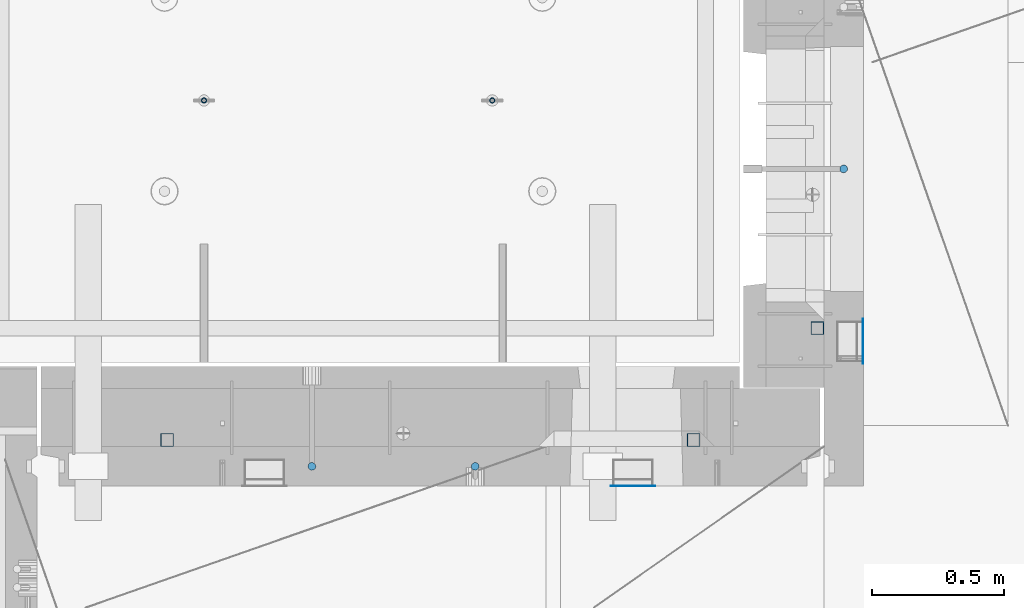
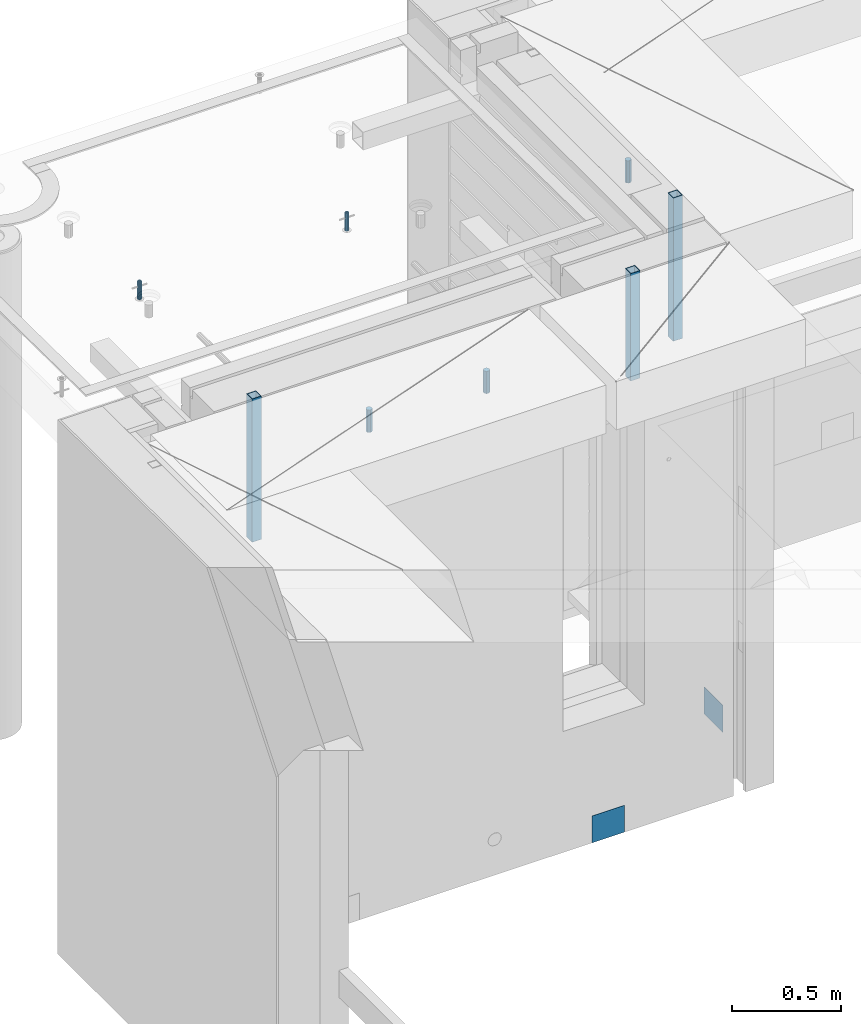
# One storey, part 27 of 350: 10 columns, 10 elements without a shape of their own.
"""IFC2X3 building model written with IfcOpenShell, lengths in millimetres."""

from ifc_helpers import new_model, si_unit, frame, origin_with_axes, place, context, subcontext, project, spatial, faceted_brep, material, type_object, element, aggregate, save


model = new_model("IFC2X3")

# Units and contexts
model_context = context("Model", 3, precision=1e-05, world=origin_with_axes())
body_context = subcontext(model_context, "Body", "Model", "MODEL_VIEW")
ifc_project = project(units=[si_unit("LENGTHUNIT", "METRE", prefix="MILLI"), si_unit("AREAUNIT", "SQUARE_METRE"), si_unit("VOLUMEUNIT", "CUBIC_METRE"), si_unit("MASSUNIT", "GRAM", prefix="KILO"), si_unit("TIMEUNIT", "SECOND"), si_unit("PLANEANGLEUNIT", "RADIAN"), si_unit("SOLIDANGLEUNIT", "STERADIAN"), si_unit("THERMODYNAMICTEMPERATUREUNIT", "DEGREE_CELSIUS"), si_unit("LUMINOUSINTENSITYUNIT", "LUMEN")], contexts=[model_context])

# Site, building, storey
site_placement = place(None, origin_with_axes())
site = spatial("IfcSite", under=ifc_project, at=site_placement, CompositionType="ELEMENT")
building_placement = place(site_placement, origin_with_axes())
building = spatial("IfcBuilding", under=site, at=building_placement, CompositionType="ELEMENT")
storey_placement = place(building_placement, origin_with_axes())
storey = spatial("IfcBuildingStorey", under=building, at=storey_placement, Name="2", CompositionType="ELEMENT", Elevation=0.0)

# Assembly, column
assembly_1_placement = place(storey_placement, origin_with_axes())
assembly_1 = element("IfcElementAssembly", 1, at=assembly_1_placement, inside=storey, AssemblyPlace="NOTDEFINED", PredefinedType="REINFORCEMENT_UNIT")
ifc_material_1 = material()
column_type_1 = type_object("IfcColumnType", Name="D30", PredefinedType="NOTDEFINED")
column_1_placement = place(assembly_1_placement, frame((11064.9999999907, 21634.9982799657, 87407.5), z_axis=(1.0, 0.0, 0.0), x_axis=(0.0, 0.0, 1.0)))
column_1 = element("IfcColumn", 2, at=column_1_placement, type_object=column_type_1, material=ifc_material_1, ObjectType="D30", context=body_context, shape_type="Brep", body=[
    faceted_brep([(0.0, -15.0, 0.0), (0.0, -12.9903810567666, -7.5), (125.0, -12.9903810567666, -7.5), (125.0, -15.0, 0.0), (0.0, -7.5, -12.9903810567666), (125.0, -7.5, -12.9903810567666), (0.0, 0.0, -15.0), (125.0, 0.0, -15.0), (0.0, 7.5, -12.9903810567666), (125.0, 7.5, -12.9903810567666), (0.0, 12.9903810567666, -7.5), (125.0, 12.9903810567666, -7.5), (0.0, 15.0, 0.0), (125.0, 15.0, 0.0), (0.0, 12.9903810567666, 7.5), (125.0, 12.9903810567666, 7.5), (0.0, 7.5, 12.9903810567666), (125.0, 7.5, 12.9903810567666), (0.0, 0.0, 15.0), (125.0, 0.0, 15.0), (0.0, -7.5, 12.9903810567666), (125.0, -7.5, 12.9903810567666), (0.0, -12.9903810567666, 7.5), (125.0, -12.9903810567666, 7.5)], [[[0, 1, 2, 3]], [[1, 4, 5, 2]], [[4, 6, 7, 5]], [[6, 8, 9, 7]], [[8, 10, 11, 9]], [[10, 12, 13, 11]], [[12, 14, 15, 13]], [[14, 16, 17, 15]], [[16, 18, 19, 17]], [[18, 20, 21, 19]], [[20, 22, 23, 21]], [[22, 0, 3, 23]], [[5, 7, 9, 11, 13, 15, 17, 19, 21, 23, 3, 2]], [[22, 20, 18, 16, 14, 12, 10, 8, 6, 4, 1, 0]]]),
])

# Assembly, columns
assembly_2_placement = place(storey_placement, origin_with_axes())
assembly_2 = element("IfcElementAssembly", 3, at=assembly_2_placement, inside=storey, AssemblyPlace="NOTDEFINED", PredefinedType="REINFORCEMENT_UNIT")
column_2_placement = place(assembly_2_placement, frame((9665.00172003435, 20504.9951872276, 87407.5), z_axis=(0.0, 1.0, 0.0), x_axis=(0.0, 0.0, 1.0)))
column_2 = element("IfcColumn", 4, at=column_2_placement, type_object=column_type_1, material=ifc_material_1, ObjectType="D30", context=body_context, shape_type="Brep", body=[
    faceted_brep([(0.0, -15.0, 0.0), (0.0, -12.9903810567666, -7.5), (125.0, -12.9903810567666, -7.5), (125.0, -15.0, 0.0), (0.0, -7.5, -12.9903810567666), (125.0, -7.5, -12.9903810567666), (0.0, 0.0, -15.0), (125.0, 0.0, -15.0), (0.0, 7.5, -12.9903810567666), (125.0, 7.5, -12.9903810567666), (0.0, 12.9903810567666, -7.5), (125.0, 12.9903810567666, -7.5), (0.0, 15.0, 0.0), (125.0, 15.0, 0.0), (0.0, 12.9903810567666, 7.5), (125.0, 12.9903810567666, 7.5), (0.0, 7.5, 12.9903810567666), (125.0, 7.5, 12.9903810567666), (0.0, 0.0, 15.0), (125.0, 0.0, 15.0), (0.0, -7.5, 12.9903810567666), (125.0, -7.5, 12.9903810567666), (0.0, -12.9903810567666, 7.5), (125.0, -12.9903810567666, 7.5)], [[[0, 1, 2, 3]], [[1, 4, 5, 2]], [[4, 6, 7, 5]], [[6, 8, 9, 7]], [[8, 10, 11, 9]], [[10, 12, 13, 11]], [[12, 14, 15, 13]], [[14, 16, 17, 15]], [[16, 18, 19, 17]], [[18, 20, 21, 19]], [[20, 22, 23, 21]], [[22, 0, 3, 23]], [[5, 7, 9, 11, 13, 15, 17, 19, 21, 23, 3, 2]], [[22, 20, 18, 16, 14, 12, 10, 8, 6, 4, 1, 0]]]),
])
column_3_placement = place(assembly_2_placement, frame((9045.00366673532, 20504.9951872205, 87407.5), z_axis=(0.0, -1.0, 0.0), x_axis=(0.0, 0.0, 1.0)))
column_3 = element("IfcColumn", 5, at=column_3_placement, type_object=column_type_1, material=ifc_material_1, ObjectType="D30", context=body_context, shape_type="Brep", body=[
    faceted_brep([(0.0, -15.0, 0.0), (0.0, -12.9903810567666, -7.5), (125.0, -12.9903810567666, -7.5), (125.0, -15.0, 0.0), (0.0, -7.5, -12.9903810567666), (125.0, -7.5, -12.9903810567666), (0.0, 0.0, -15.0), (125.0, 0.0, -15.0), (0.0, 7.5, -12.9903810567666), (125.0, 7.5, -12.9903810567666), (0.0, 12.9903810567666, -7.5), (125.0, 12.9903810567666, -7.5), (0.0, 15.0, 0.0), (125.0, 15.0, 0.0), (0.0, 12.9903810567666, 7.5), (125.0, 12.9903810567666, 7.5), (0.0, 7.5, 12.9903810567666), (125.0, 7.5, 12.9903810567666), (0.0, 0.0, 15.0), (125.0, 0.0, 15.0), (0.0, -7.5, 12.9903810567666), (125.0, -7.5, 12.9903810567666), (0.0, -12.9903810567666, 7.5), (125.0, -12.9903810567666, 7.5)], [[[0, 1, 2, 3]], [[1, 4, 5, 2]], [[4, 6, 7, 5]], [[6, 8, 9, 7]], [[8, 10, 11, 9]], [[10, 12, 13, 11]], [[12, 14, 15, 13]], [[14, 16, 17, 15]], [[16, 18, 19, 17]], [[18, 20, 21, 19]], [[20, 22, 23, 21]], [[22, 0, 3, 23]], [[5, 7, 9, 11, 13, 15, 17, 19, 21, 23, 3, 2]], [[22, 20, 18, 16, 14, 12, 10, 8, 6, 4, 1, 0]]]),
])

# Assembly, column
assembly_3_placement = place(assembly_1_placement, origin_with_axes())
assembly_3 = element("IfcElementAssembly", 6, at=assembly_3_placement, Name="Steel Assembly", AssemblyPlace="NOTDEFINED", PredefinedType="NOTDEFINED")
ifc_material_2 = material(Name="Undefined")
column_type_2 = type_object("IfcColumnType", PredefinedType="NOTDEFINED")
column_4_placement = place(assembly_3_placement, frame((11139.0000000031, 20979.9951872276, 84754.9999999969), z_axis=(1.0, 0.0, 0.0), x_axis=(0.0, 0.0, 1.0)))
column_4 = element("IfcColumn", 7, at=column_4_placement, type_object=column_type_2, material=ifc_material_2, Name="SPK2", context=body_context, shape_type="Brep", body=[
    faceted_brep([(0.0, 85.0, -1.0), (0.0, 85.0, 1.0), (150.0, 85.0, 1.0), (150.0, 85.0, -1.0), (0.0, -85.0, 1.0), (150.0, -85.0, 1.0), (0.0, -85.0, -1.0), (150.0, -85.0, -1.0)], [[[0, 1, 2, 3]], [[1, 4, 5, 2]], [[4, 6, 7, 5]], [[6, 0, 3, 7]], [[5, 7, 3, 2]], [[6, 4, 1, 0]]]),
])
aggregate(assembly_3, [column_4])

assembly_4_placement = place(assembly_2_placement, origin_with_axes())
assembly_4 = element("IfcElementAssembly", 8, at=assembly_4_placement, Name="Steel Assembly", AssemblyPlace="NOTDEFINED", PredefinedType="NOTDEFINED")
column_5_placement = place(assembly_4_placement, frame((10265.0, 20430.9951872214, 84755.0), z_axis=(0.0, -1.0, 0.0), x_axis=(0.0, 0.0, 1.0)))
column_5 = element("IfcColumn", 9, at=column_5_placement, type_object=column_type_2, material=ifc_material_2, Name="SPK2", context=body_context, shape_type="Brep", body=[
    faceted_brep([(0.0, 85.0, -1.0), (0.0, 85.0, 1.0), (150.0, 85.0, 1.0), (150.0, 85.0, -1.0), (0.0, -85.0, 1.0), (150.0, -85.0, 1.0), (0.0, -85.0, -1.0), (150.0, -85.0, -1.0)], [[[0, 1, 2, 3]], [[1, 4, 5, 2]], [[4, 6, 7, 5]], [[6, 0, 3, 7]], [[5, 7, 3, 2]], [[6, 4, 1, 0]]]),
])
aggregate(assembly_4, [column_5])

# Assembly
assembly_5_placement = place(assembly_1_placement, origin_with_axes())
assembly_5 = element("IfcElementAssembly", 10, at=assembly_5_placement, Name="Steel Assembly", AssemblyPlace="NOTDEFINED", PredefinedType="RIGID_FRAME")

aggregate(assembly_1, [column_1, assembly_3, assembly_5])

# Column
ifc_material_3 = material(Name="STEEL/S355J2")
column_type_3 = type_object("IfcColumnType", Name="50X50X3", PredefinedType="NOTDEFINED")
column_6_placement = place(assembly_5_placement, frame((10965.0, 21030.0, 86940.0), z_axis=(1.0, 0.0, 0.0), x_axis=(0.0, 0.0, 1.0)))
column_6 = element("IfcColumn", 11, at=column_6_placement, type_object=column_type_3, material=ifc_material_3, ObjectType="50X50X3", context=body_context, shape_type="Brep", body=[
    faceted_brep([(0.0, 22.0, -22.0), (0.0, -22.0, -22.0), (800.0, -22.0, -22.0), (800.0, 22.0, -22.0), (0.0, -22.0, 22.0), (800.0, -22.0, 22.0), (0.0, 22.0, 22.0), (800.0, 22.0, 22.0), (0.0, 25.0, -25.0), (0.0, 25.0, 25.0), (800.0, 25.0, 25.0), (800.0, 25.0, -25.0), (0.0, -25.0, 25.0), (800.0, -25.0, 25.0), (0.0, -25.0, -25.0), (800.0, -25.0, -25.0)], [[[0, 1, 2, 3]], [[1, 4, 5, 2]], [[4, 6, 7, 5]], [[6, 0, 3, 7]], [[8, 9, 10, 11]], [[9, 12, 13, 10]], [[12, 14, 15, 13]], [[14, 8, 11, 15]], [[13, 15, 11, 10], [5, 7, 3, 2]], [[14, 12, 9, 8], [6, 4, 1, 0]]]),
])

aggregate(assembly_5, [column_6])

# Assembly, column
assembly_6_placement = place(assembly_2_placement, origin_with_axes())
assembly_6 = element("IfcElementAssembly", 12, at=assembly_6_placement, Name="Steel Assembly", AssemblyPlace="NOTDEFINED", PredefinedType="RIGID_FRAME")
column_7_placement = place(assembly_6_placement, frame((8495.0, 20605.0, 86940.0), z_axis=(1.0, 0.0, 0.0), x_axis=(0.0, 0.0, 1.0)))
column_7 = element("IfcColumn", 13, at=column_7_placement, type_object=column_type_3, material=ifc_material_3, ObjectType="50X50X3", context=body_context, shape_type="Brep", body=[
    faceted_brep([(0.0, 22.0, -22.0), (0.0, -22.0, -22.0), (800.0, -22.0, -22.0), (800.0, 22.0, -22.0), (0.0, -22.0, 22.0), (800.0, -22.0, 22.0), (0.0, 22.0, 22.0), (800.0, 22.0, 22.0), (0.0, 25.0, -25.0), (0.0, 25.0, 25.0), (800.0, 25.0, 25.0), (800.0, 25.0, -25.0), (0.0, -25.0, 25.0), (800.0, -25.0, 25.0), (0.0, -25.0, -25.0), (800.0, -25.0, -25.0)], [[[0, 1, 2, 3]], [[1, 4, 5, 2]], [[4, 6, 7, 5]], [[6, 0, 3, 7]], [[8, 9, 10, 11]], [[9, 12, 13, 10]], [[12, 14, 15, 13]], [[14, 8, 11, 15]], [[13, 15, 11, 10], [5, 7, 3, 2]], [[14, 12, 9, 8], [6, 4, 1, 0]]]),
])
aggregate(assembly_6, [column_7])

# Assembly
assembly_7_placement = place(assembly_2_placement, origin_with_axes())
assembly_7 = element("IfcElementAssembly", 14, at=assembly_7_placement, Name="Steel Assembly", AssemblyPlace="NOTDEFINED", PredefinedType="RIGID_FRAME")

aggregate(assembly_2, [column_2, column_3, assembly_4, assembly_6, assembly_7])

# Column
column_8_placement = place(assembly_7_placement, frame((10495.0, 20605.0, 87140.0), z_axis=(1.0, 0.0, 0.0), x_axis=(0.0, 0.0, 1.0)))
column_8 = element("IfcColumn", 15, at=column_8_placement, type_object=column_type_3, material=ifc_material_3, ObjectType="50X50X3", context=body_context, shape_type="Brep", body=[
    faceted_brep([(0.0, 22.0, -22.0), (0.0, -22.0, -22.0), (600.0, -22.0, -22.0), (600.0, 22.0, -22.0), (0.0, -22.0, 22.0), (600.0, -22.0, 22.0), (0.0, 22.0, 22.0), (600.0, 22.0, 22.0), (0.0, 25.0, -25.0), (0.0, 25.0, 25.0), (600.0, 25.0, 25.0), (600.0, 25.0, -25.0), (0.0, -25.0, 25.0), (600.0, -25.0, 25.0), (0.0, -25.0, -25.0), (600.0, -25.0, -25.0)], [[[0, 1, 2, 3]], [[1, 4, 5, 2]], [[4, 6, 7, 5]], [[6, 0, 3, 7]], [[8, 9, 10, 11]], [[9, 12, 13, 10]], [[12, 14, 15, 13]], [[14, 8, 11, 15]], [[13, 15, 11, 10], [5, 7, 3, 2]], [[14, 12, 9, 8], [6, 4, 1, 0]]]),
])

aggregate(assembly_7, [column_8])

# Assemblies, columns
assembly_8_placement = place(storey_placement, origin_with_axes())
assembly_8 = element("IfcElementAssembly", 16, at=assembly_8_placement, inside=storey, AssemblyPlace="NOTDEFINED", PredefinedType="REINFORCEMENT_UNIT")
assembly_9_placement = place(assembly_8_placement, origin_with_axes())
assembly_9 = element("IfcElementAssembly", 17, at=assembly_9_placement, Name="Steel Assembly", AssemblyPlace="NOTDEFINED", PredefinedType="RIGID_FRAME")
ifc_material_4 = material(Name="STEEL/1.4301")
column_type_4 = type_object("IfcColumnType", PredefinedType="NOTDEFINED")
column_9_placement = place(assembly_9_placement, frame((8634.9865866494, 21895.0212615308, 87444.9999983246), z_axis=(-1.60829999983552e-05, -0.999999999870669, 0.0), x_axis=(0.0, 0.0, 1.0)))
column_9 = element("IfcColumn", 18, at=column_9_placement, type_object=column_type_4, material=ifc_material_4, context=body_context, shape_type="Brep", body=[
    faceted_brep([(0.0, -8.0, 0.0), (0.0, -6.92820323027263, 4.0), (100.000000000029, -6.92820323027263, 4.0), (100.000000000029, -7.99999999999636, 0.0), (0.0, -4.0, 6.92820323027627), (100.000000000029, -4.0, 6.92820323027536), (0.0, 0.0, 8.0), (100.000000000029, 3.63797880709171e-12, 8.0), (0.0, 4.0, 6.92820323027627), (100.000000000029, 4.0, 6.92820323027536), (0.0, 6.92820323027263, 4.0), (100.000000000029, 6.92820323027627, 3.99999999999909), (0.0, 8.0, 0.0), (100.000000000029, 8.0, 0.0), (0.0, 6.92820323027263, -4.0), (100.000000000029, 6.92820323027627, -4.00000000000091), (0.0, 4.0, -6.92820323027627), (100.000000000029, 4.00000000000364, -6.92820323027536), (0.0, 0.0, -8.0), (100.000000000029, 3.63797880709171e-12, -8.00000000000091), (0.0, -4.0, -6.92820323027627), (100.000000000029, -3.99999999999636, -6.92820323027627), (0.0, -6.92820323027263, -4.0), (100.000000000029, -6.92820323027263, -4.0), (0.0, -10.4999999999927, -1.45519152283669e-11), (0.0, -9.09326673972828, -5.25000000001455), (100.000000000262, -9.09326673972828, -5.25000000001455), (100.000000000262, -10.4999999999927, -1.45519152283669e-11), (0.0, -5.24999999998545, -9.09326673974283), (100.000000000262, -5.24999999998545, -9.09326673974283), (0.0, 7.27595761418343e-12, -10.5), (100.000000000262, 7.27595761418343e-12, -10.5), (0.0, 5.25000000001455, -9.09326673975738), (100.000000000262, 5.25000000001455, -9.09326673975738), (0.0, 9.09326673975011, -5.25000000001455), (100.000000000262, 9.09326673975011, -5.25000000001455), (0.0, 10.5000000000073, -1.45519152283669e-11), (100.000000000262, 10.5000000000073, -1.45519152283669e-11), (0.0, 9.09326673975011, 5.25), (100.000000000262, 9.09326673975011, 5.25), (0.0, 5.25000000000728, 9.09326673972828), (100.000000000262, 5.25000000000728, 9.09326673972828), (0.0, 1.45519152283669e-11, 10.4999999999854), (100.000000000262, 1.45519152283669e-11, 10.4999999999854), (0.0, -5.24999999999272, 9.09326673972828), (100.000000000262, -5.24999999999272, 9.09326673972828), (0.0, -9.09326673972828, 5.24999999998545), (100.000000000262, -9.09326673972828, 5.24999999998545)], [[[0, 1, 2, 3]], [[1, 4, 5, 2]], [[4, 6, 7, 5]], [[6, 8, 9, 7]], [[8, 10, 11, 9]], [[10, 12, 13, 11]], [[12, 14, 15, 13]], [[14, 16, 17, 15]], [[16, 18, 19, 17]], [[18, 20, 21, 19]], [[20, 22, 23, 21]], [[22, 0, 3, 23]], [[24, 25, 26, 27]], [[25, 28, 29, 26]], [[28, 30, 31, 29]], [[30, 32, 33, 31]], [[32, 34, 35, 33]], [[34, 36, 37, 35]], [[36, 38, 39, 37]], [[38, 40, 41, 39]], [[40, 42, 43, 41]], [[42, 44, 45, 43]], [[44, 46, 47, 45]], [[46, 24, 27, 47]], [[29, 31, 33, 35, 37, 39, 41, 43, 45, 47, 27, 26], [5, 7, 9, 11, 13, 15, 17, 19, 21, 23, 3, 2]], [[46, 44, 42, 40, 38, 36, 34, 32, 30, 28, 25, 24], [22, 20, 18, 16, 14, 12, 10, 8, 6, 4, 1, 0]]]),
])
aggregate(assembly_9, [column_9])
assembly_10_placement = place(assembly_8_placement, origin_with_axes())
assembly_10 = element("IfcElementAssembly", 19, at=assembly_10_placement, Name="Steel Assembly", AssemblyPlace="NOTDEFINED", PredefinedType="RIGID_FRAME")
aggregate(assembly_8, [assembly_9, assembly_10])
column_10_placement = place(assembly_10_placement, frame((9729.98658651215, 21895.0041915483, 87444.9999983246), z_axis=(-1.60829999983552e-05, -0.999999999870669, 0.0), x_axis=(0.0, 0.0, 1.0)))
column_10 = element("IfcColumn", 20, at=column_10_placement, type_object=column_type_4, material=ifc_material_4, context=body_context, shape_type="Brep", body=[
    faceted_brep([(0.0, -8.0, 0.0), (0.0, -6.92820323027263, 4.0), (100.000000000029, -6.92820323027263, 4.0), (100.000000000029, -7.99999999999636, 0.0), (0.0, -4.0, 6.92820323027627), (100.000000000029, -4.0, 6.92820323027536), (0.0, 0.0, 8.0), (100.000000000029, 3.63797880709171e-12, 8.0), (0.0, 4.0, 6.92820323027627), (100.000000000029, 4.0, 6.92820323027536), (0.0, 6.92820323027263, 4.0), (100.000000000029, 6.92820323027627, 3.99999999999909), (0.0, 8.0, 0.0), (100.000000000029, 8.0, 0.0), (0.0, 6.92820323027263, -4.0), (100.000000000029, 6.92820323027627, -4.00000000000091), (0.0, 4.0, -6.92820323027627), (100.000000000029, 4.00000000000364, -6.92820323027536), (0.0, 0.0, -8.0), (100.000000000029, 3.63797880709171e-12, -8.00000000000091), (0.0, -4.0, -6.92820323027627), (100.000000000029, -3.99999999999636, -6.92820323027627), (0.0, -6.92820323027263, -4.0), (100.000000000029, -6.92820323027263, -4.0), (0.0, -10.4999999999927, -1.45519152283669e-11), (0.0, -9.09326673972828, -5.25000000001455), (100.000000000262, -9.09326673972828, -5.25000000001455), (100.000000000262, -10.4999999999927, -1.45519152283669e-11), (0.0, -5.24999999998545, -9.09326673974283), (100.000000000262, -5.24999999998545, -9.09326673974283), (0.0, 7.27595761418343e-12, -10.5), (100.000000000262, 7.27595761418343e-12, -10.5), (0.0, 5.25000000001455, -9.09326673975738), (100.000000000262, 5.25000000001455, -9.09326673975738), (0.0, 9.09326673975011, -5.25000000001455), (100.000000000262, 9.09326673975011, -5.25000000001455), (0.0, 10.5000000000073, -1.45519152283669e-11), (100.000000000262, 10.5000000000073, -1.45519152283669e-11), (0.0, 9.09326673975011, 5.25), (100.000000000262, 9.09326673975011, 5.25), (0.0, 5.25000000000728, 9.09326673972828), (100.000000000262, 5.25000000000728, 9.09326673972828), (0.0, 1.45519152283669e-11, 10.4999999999854), (100.000000000262, 1.45519152283669e-11, 10.4999999999854), (0.0, -5.24999999999272, 9.09326673972828), (100.000000000262, -5.24999999999272, 9.09326673972828), (0.0, -9.09326673972828, 5.24999999998545), (100.000000000262, -9.09326673972828, 5.24999999998545)], [[[0, 1, 2, 3]], [[1, 4, 5, 2]], [[4, 6, 7, 5]], [[6, 8, 9, 7]], [[8, 10, 11, 9]], [[10, 12, 13, 11]], [[12, 14, 15, 13]], [[14, 16, 17, 15]], [[16, 18, 19, 17]], [[18, 20, 21, 19]], [[20, 22, 23, 21]], [[22, 0, 3, 23]], [[24, 25, 26, 27]], [[25, 28, 29, 26]], [[28, 30, 31, 29]], [[30, 32, 33, 31]], [[32, 34, 35, 33]], [[34, 36, 37, 35]], [[36, 38, 39, 37]], [[38, 40, 41, 39]], [[40, 42, 43, 41]], [[42, 44, 45, 43]], [[44, 46, 47, 45]], [[46, 24, 27, 47]], [[29, 31, 33, 35, 37, 39, 41, 43, 45, 47, 27, 26], [5, 7, 9, 11, 13, 15, 17, 19, 21, 23, 3, 2]], [[46, 44, 42, 40, 38, 36, 34, 32, 30, 28, 25, 24], [22, 20, 18, 16, 14, 12, 10, 8, 6, 4, 1, 0]]]),
])
aggregate(assembly_10, [column_10])

save(model, "model.ifc")
